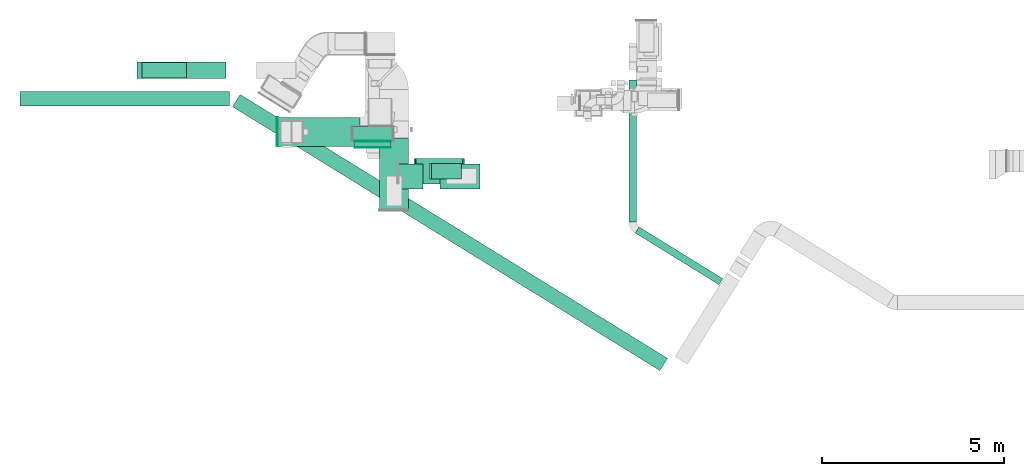
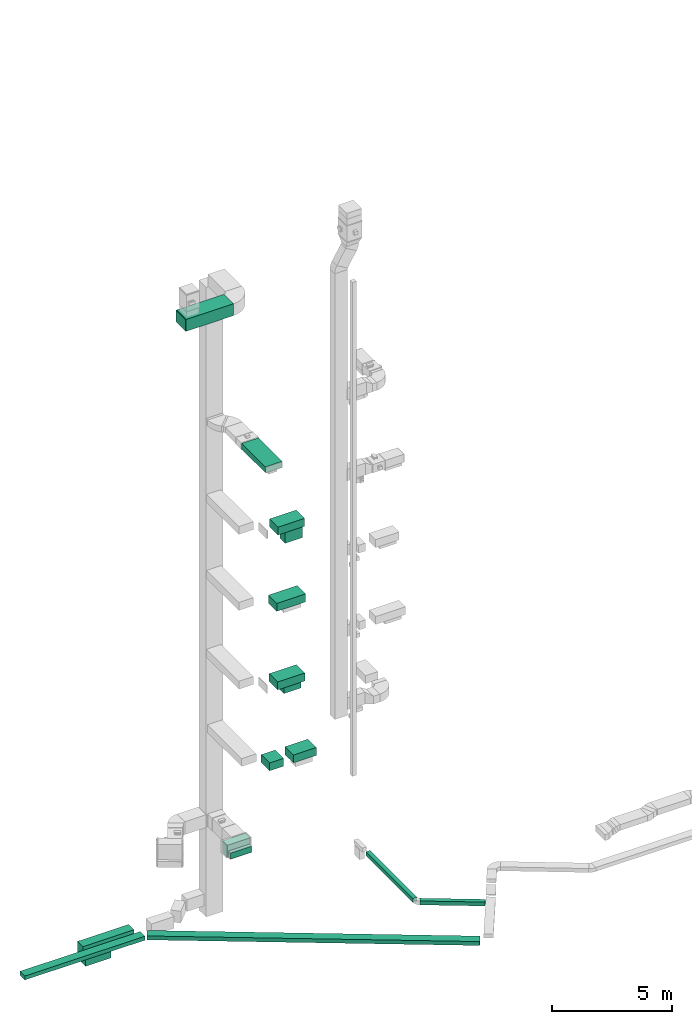
# One storey, part 5 of 25: 17 flow segments, 2 flow fittings, 1 flow terminal.
"""IFC2X3 building model written with IfcOpenShell, lengths in millimetres."""

import ifcopenshell
import ifcopenshell.guid

model = None  # the IFC model being written
_history = None  # IfcOwnerHistory: only IFC2X3 demands one
_inside = {}  # id of a spatial element -> (the spatial element, [elements in it])
_under = {}  # id of a project, library or spatial element -> (it, [spatial elements below it])
_declared = {}  # id of a project -> (the project, [libraries it declares])
_typed = {}  # id of a type object -> (the type object, [elements of that type])
_made_of = {}  # id of a material, layer set ... -> (it, [elements and type objects made of it])


def new_model(schema):
    """Start an empty IFC model of exactly this schema.

    Asked for "IFC4X3", IfcOpenShell would pick the latest addendum, in which some entities
    have other attributes; the version numbers below select the first issue.
    IFC2X3 requires an IfcOwnerHistory on every rooted entity: one is made here for all.
    """
    global model, _history
    if schema == "IFC4X3":
        model = ifcopenshell.file(schema_version=(4, 3, 0, 0))
    else:
        model = ifcopenshell.file(schema=schema)
    _inside.clear()
    _under.clear()
    _declared.clear()
    _typed.clear()
    _made_of.clear()
    _history = None
    if model.schema == "IFC2X3":
        org = make("IfcOrganization", Name="unknown")
        user = make(
            "IfcPersonAndOrganization",
            ThePerson=make("IfcPerson", FamilyName="unknown"),
            TheOrganization=org,
        )
        app = make(
            "IfcApplication",
            ApplicationDeveloper=org,
            Version="unknown",
            ApplicationFullName="unknown",
            ApplicationIdentifier="unknown",
        )
        _history = make(
            "IfcOwnerHistory",
            OwningUser=user,
            OwningApplication=app,
            ChangeAction="ADDED",
            CreationDate=0,
        )
    return model


def make(cls, **values):
    """One entity of the class cls with the attributes given. An attribute that is None is left unset."""
    return model.create_entity(
        cls, **{name: value for name, value in values.items() if value is not None}
    )


def entity(cls, *values):
    """Any entity or typed value of the class cls, its attributes in the order of the schema. None: left unset."""
    e = model.create_entity(cls)
    for i, value in enumerate(values):
        if value is not None:
            e[i] = value
    return e


def rooted(cls, **values):
    """An entity with a GlobalId (a new one), such as an element, a storey or a relation."""
    return make(cls, GlobalId=ifcopenshell.guid.new(), OwnerHistory=_history, **values)


def si_unit(unit_type, name, prefix=None):
    """IfcSIUnit, for example si_unit("LENGTHUNIT", "METRE", prefix="MILLI")."""
    return make("IfcSIUnit", UnitType=unit_type, Prefix=prefix, Name=name)


def converted_unit(unit_type, name, factor, base, dimensions=None, offset=None):
    """IfcConversionBasedUnit, such as the inch: factor (a typed value) times the base unit."""
    return make(
        "IfcConversionBasedUnit"
        if offset is None
        else "IfcConversionBasedUnitWithOffset",
        ConversionOffset=offset,
        Dimensions=None
        if dimensions is None
        else entity("IfcDimensionalExponents", *dimensions),
        UnitType=unit_type,
        Name=name,
        ConversionFactor=make(
            "IfcMeasureWithUnit", ValueComponent=factor, UnitComponent=base
        ),
    )


def derived_unit(unit_type, elements):
    """IfcDerivedUnit: a product of units, each with its exponent."""
    return make(
        "IfcDerivedUnit",
        Elements=[
            make("IfcDerivedUnitElement", Unit=unit, Exponent=power)
            for unit, power in elements
        ],
        UnitType=unit_type,
    )


def assignment(units):
    """IfcUnitAssignment: the units of a project."""
    return None if units is None else make("IfcUnitAssignment", Units=units)


def point(xyz):
    """IfcCartesianPoint."""
    return None if xyz is None else make("IfcCartesianPoint", Coordinates=xyz)


def direction(xyz):
    """IfcDirection."""
    return None if xyz is None else make("IfcDirection", DirectionRatios=xyz)


def frame(location, z_axis=None, x_axis=None):
    """IfcAxis2Placement3D, a coordinate frame: its origin and axes. An axis left out is left unset."""
    return make(
        "IfcAxis2Placement3D",
        Location=point(location),
        Axis=direction(z_axis),
        RefDirection=direction(x_axis),
    )


def frame_2d(location, x_axis=None):
    """IfcAxis2Placement2D, a coordinate frame in the plane: its origin and x axis."""
    return make(
        "IfcAxis2Placement2D", Location=point(location), RefDirection=direction(x_axis)
    )


def origin():
    """The frame at (0, 0, 0) with its axes left unset."""
    return frame((0.0, 0.0, 0.0))


def origin_2d_with_axis():
    """The frame at (0, 0) in the plane with the x axis (1, 0) written out."""
    return frame_2d((0.0, 0.0), x_axis=(1.0, 0.0))


def place(relative_to, where):
    """IfcLocalPlacement: puts the frame where relative to a parent placement (None: the world)."""
    return make(
        "IfcLocalPlacement", PlacementRelTo=relative_to, RelativePlacement=where
    )


def context(
    kind, dimensions, precision=None, world=None, true_north=None, identifier=None
):
    """IfcGeometricRepresentationContext, for example the 3D "Model" context."""
    return make(
        "IfcGeometricRepresentationContext",
        ContextIdentifier=identifier,
        ContextType=kind,
        CoordinateSpaceDimension=dimensions,
        Precision=precision,
        WorldCoordinateSystem=world,
        TrueNorth=true_north,
    )


def subcontext(parent, identifier, kind, view, scale=None):
    """IfcGeometricRepresentationSubContext, for example "Body" below "Model"."""
    return make(
        "IfcGeometricRepresentationSubContext",
        ContextIdentifier=identifier,
        ContextType=kind,
        ParentContext=parent,
        TargetScale=scale,
        TargetView=view,
    )


def project(units=None, contexts=None):
    """IfcProject with its units and contexts."""
    return rooted(
        "IfcProject",
        Name="project",
        RepresentationContexts=contexts,
        UnitsInContext=assignment(units),
    )


def spatial(cls, under=None, at=None, **own):
    """A site, building, storey or space (cls), placed at a placement, below another one or the project."""
    s = rooted(cls, ObjectPlacement=at, **own)
    if under is not None:
        _under.setdefault(under.id(), (under, []))[1].append(s)
    return s


def profile(cls, at=None, kind="AREA", **sizes):
    """A parametric profile (cls). Its sizes go by their IFC names, for example OverallWidth=200.0."""
    return make(cls, ProfileType=kind, Position=at, **sizes)


def rectangle(**sizes):
    """IfcRectangleProfileDef."""
    return profile("IfcRectangleProfileDef", **sizes)


def extrude(swept, where, along, depth):
    """IfcExtrudedAreaSolid: the profile swept, set in the frame where, extruded along a direction by depth."""
    return make(
        "IfcExtrudedAreaSolid",
        SweptArea=swept,
        Position=where,
        ExtrudedDirection=direction(along),
        Depth=depth,
    )


def shape(context_of_items, identifier, shape_type, items):
    """IfcShapeRepresentation: the items that make up one representation, for example the "Body"."""
    return make(
        "IfcShapeRepresentation",
        ContextOfItems=context_of_items,
        RepresentationIdentifier=identifier,
        RepresentationType=shape_type,
        Items=items,
    )


def source(mapping_origin, context_of_items, identifier, shape_type, items):
    """IfcRepresentationMap: a shape defined once, which mapped items show again and again."""
    return make(
        "IfcRepresentationMap",
        MappingOrigin=mapping_origin,
        MappedRepresentation=shape(context_of_items, identifier, shape_type, items),
    )


def transform(
    local_origin,
    x_axis=None,
    y_axis=None,
    z_axis=None,
    scale=None,
    scale2=None,
    scale3=None,
    uniform=True,
):
    """IfcCartesianTransformationOperator3D, or its non-uniform kind. x_axis, y_axis, z_axis: its Axis1, 2, 3."""
    if uniform:
        return make(
            "IfcCartesianTransformationOperator3D",
            Axis1=direction(x_axis),
            Axis2=direction(y_axis),
            LocalOrigin=point(local_origin),
            Scale=scale,
            Axis3=direction(z_axis),
        )
    return make(
        "IfcCartesianTransformationOperator3DnonUniform",
        Axis1=direction(x_axis),
        Axis2=direction(y_axis),
        LocalOrigin=point(local_origin),
        Scale=scale,
        Axis3=direction(z_axis),
        Scale2=scale2,
        Scale3=scale3,
    )


def mapped(mapping_source, mapping_target):
    """IfcMappedItem: shows the shape of a source again, moved by a transform."""
    return make(
        "IfcMappedItem", MappingSource=mapping_source, MappingTarget=mapping_target
    )


def material(Name=None, Category=None):
    """IfcMaterial."""
    return make("IfcMaterial", Name=Name, Category=Category)


def made_of(thing, what):
    """Note that an element or type object is made of a material, layer set ...; save() writes the relation."""
    if what is not None:
        _made_of.setdefault(what.id(), (what, []))[1].append(thing)
    return thing


def type_object(cls, material=None, **own):
    """A type object (cls), such as IfcWallType, which elements share."""
    return made_of(rooted(cls, **own), material)


def type_shapes(of_type, sources):
    """Give a type object the sources (RepresentationMaps) that its elements show as mapped items."""
    of_type.RepresentationMaps = sources


def element(
    cls,
    number,
    at=None,
    inside=None,
    cuts=None,
    type_object=None,
    material=None,
    context=None,
    identifier="Body",
    shape_type=None,
    held_by="IfcProductDefinitionShape",
    body=None,
    shapes=None,
    **own,
):
    """One element of the class cls, such as IfcWall. Its Tag is "e" and its number.

    at: its placement. inside: the storey or other place that contains it. cuts: it is an
    opening in that element (IfcRelVoidsElement). A single representation is given by context,
    identifier, shape_type and body (its items); several are given by shapes. held_by: the class
    of the entity that holds the representations. save() writes the other relations.
    """
    e = rooted(cls, Tag="e%d" % number, ObjectPlacement=at, **own)
    if body is not None:
        shapes = [shape(context, identifier, shape_type, body)]
    if shapes is not None:
        e.Representation = make(held_by, Representations=shapes)
    if inside is not None:
        _inside.setdefault(inside.id(), (inside, []))[1].append(e)
    if cuts is not None:
        rooted(
            "IfcRelVoidsElement", RelatingBuildingElement=cuts, RelatedOpeningElement=e
        )
    if type_object is not None:
        _typed.setdefault(type_object.id(), (type_object, []))[1].append(e)
    return made_of(e, material)


def aggregate(whole, parts):
    """IfcRelAggregates: a whole, such as a stair, and the parts it consists of."""
    return rooted("IfcRelAggregates", RelatingObject=whole, RelatedObjects=parts)


def save(model, path):
    """Write the relations noted so far, then the file.

    IfcRelAggregates (storeys below a building ...), IfcRelContainedInSpatialStructure (elements
    in a storey), IfcRelDefinesByType, IfcRelAssociatesMaterial and IfcRelDeclares: one each for
    every whole, place, type object, material and project.
    """
    for whole, parts in _under.values():
        aggregate(whole, parts)
    for where, things in _inside.values():
        rooted(
            "IfcRelContainedInSpatialStructure",
            RelatedElements=things,
            RelatingStructure=where,
        )
    for kind, things in _typed.values():
        rooted("IfcRelDefinesByType", RelatedObjects=things, RelatingType=kind)
    for what, things in _made_of.values():
        rooted("IfcRelAssociatesMaterial", RelatedObjects=things, RelatingMaterial=what)
    for by, libraries in _declared.values():
        rooted("IfcRelDeclares", RelatingContext=by, RelatedDefinitions=libraries)
    model.write(path)


model = new_model("IFC2X3")

# Units and contexts
model_context = context("Model", 3, precision=0.01, world=origin(), true_north=direction((6.12303176911189e-17, 1.0)))
body_context = subcontext(model_context, "Body", "Model", "MODEL_VIEW")
ifc_project = project(units=[si_unit("LENGTHUNIT", "METRE", prefix="MILLI"), si_unit("AREAUNIT", "SQUARE_METRE"), si_unit("VOLUMEUNIT", "CUBIC_METRE"), converted_unit("PLANEANGLEUNIT", "DEGREE", entity("IfcRatioMeasure", 0.0174532925199433), si_unit("PLANEANGLEUNIT", "RADIAN"), dimensions=[0, 0, 0, 0, 0, 0, 0]), si_unit("MASSUNIT", "GRAM", prefix="KILO"), derived_unit("MASSDENSITYUNIT", [(si_unit("MASSUNIT", "GRAM", prefix="KILO"), 1), (si_unit("LENGTHUNIT", "METRE"), -3)]), derived_unit("MOMENTOFINERTIAUNIT", [(si_unit("LENGTHUNIT", "METRE"), 4)]), si_unit("TIMEUNIT", "SECOND"), si_unit("FREQUENCYUNIT", "HERTZ"), si_unit("THERMODYNAMICTEMPERATUREUNIT", "DEGREE_CELSIUS"), derived_unit("THERMALTRANSMITTANCEUNIT", [(si_unit("MASSUNIT", "GRAM", prefix="KILO"), 1), (si_unit("THERMODYNAMICTEMPERATUREUNIT", "KELVIN"), -1), (si_unit("TIMEUNIT", "SECOND"), -3)]), derived_unit("VOLUMETRICFLOWRATEUNIT", [(si_unit("LENGTHUNIT", "METRE"), 3), (si_unit("TIMEUNIT", "SECOND"), -1)]), derived_unit("MASSFLOWRATEUNIT", [(si_unit("MASSUNIT", "GRAM", prefix="KILO"), 1), (si_unit("TIMEUNIT", "SECOND"), -1)]), derived_unit("ROTATIONALFREQUENCYUNIT", [(si_unit("TIMEUNIT", "SECOND"), -1)]), si_unit("ELECTRICCURRENTUNIT", "AMPERE"), si_unit("ELECTRICVOLTAGEUNIT", "VOLT"), si_unit("POWERUNIT", "WATT"), si_unit("FORCEUNIT", "NEWTON", prefix="KILO"), si_unit("ILLUMINANCEUNIT", "LUX"), si_unit("LUMINOUSFLUXUNIT", "LUMEN"), si_unit("LUMINOUSINTENSITYUNIT", "CANDELA"), derived_unit("USERDEFINED", [(si_unit("MASSUNIT", "GRAM", prefix="KILO"), -1), (si_unit("LENGTHUNIT", "METRE"), -2), (si_unit("TIMEUNIT", "SECOND"), 3), (si_unit("LUMINOUSFLUXUNIT", "LUMEN"), 1)]), derived_unit("LINEARVELOCITYUNIT", [(si_unit("LENGTHUNIT", "METRE"), 1), (si_unit("TIMEUNIT", "SECOND"), -1)]), si_unit("PRESSUREUNIT", "PASCAL"), derived_unit("USERDEFINED", [(si_unit("LENGTHUNIT", "METRE"), -2), (si_unit("MASSUNIT", "GRAM", prefix="KILO"), 1), (si_unit("TIMEUNIT", "SECOND"), -2)]), derived_unit("LINEARFORCEUNIT", [(si_unit("MASSUNIT", "GRAM", prefix="KILO"), 1), (si_unit("LENGTHUNIT", "METRE"), 1), (si_unit("TIMEUNIT", "SECOND"), -2), (si_unit("LENGTHUNIT", "METRE"), -1)]), derived_unit("PLANARFORCEUNIT", [(si_unit("MASSUNIT", "GRAM", prefix="KILO"), 1), (si_unit("LENGTHUNIT", "METRE"), 1), (si_unit("TIMEUNIT", "SECOND"), -2), (si_unit("LENGTHUNIT", "METRE"), -2)])], contexts=[model_context])

# Site, building, storey
site_placement = place(None, origin())
site = spatial("IfcSite", under=ifc_project, at=site_placement, CompositionType="ELEMENT")
building_placement = place(site_placement, origin())
building = spatial("IfcBuilding", under=site, at=building_placement, CompositionType="ELEMENT")
storey_placement = place(building_placement, origin())
storey = spatial("IfcBuildingStorey", under=building, at=storey_placement, CompositionType="ELEMENT", Elevation=0.0)

# Flow segments
duct_segment_type_1 = type_object("IfcDuctSegmentType", PredefinedType="NOTDEFINED")
flow_segment_1_placement = place(storey_placement, frame((-5375.43, 14592.06, -1100.0)))
element("IfcFlowSegment", 1, at=flow_segment_1_placement, inside=storey, type_object=duct_segment_type_1, context=body_context, shape_type="SweptSolid", body=[
    extrude(rectangle(XDim=5771.90420210275, YDim=400.0, at=origin_2d_with_axis()), frame((2885.95, 200.0, 0.0)), (0.0, 0.0, 1.0), 200.0),
])
flow_segment_2_placement = place(storey_placement, frame((11565.9, 9667.02, -1100.0)))
element("IfcFlowSegment", 2, at=flow_segment_2_placement, inside=storey, type_object=duct_segment_type_1, context=body_context, shape_type="SweptSolid", body=[
    extrude(rectangle(XDim=2711.86979617274, YDim=199.999999999998, at=origin_2d_with_axis()), frame((1206.16, 797.64, 0.0), z_axis=(0.0, 0.0, 1.0), x_axis=(0.850783354162399, -0.525516588016189, 0.0)), (0.0, 0.0, 1.0), 200.0),
])
flow_segment_3_placement = place(storey_placement, frame((3785.85, 13632.5, 2500.0)))
element("IfcFlowSegment", 3, at=flow_segment_3_placement, inside=storey, type_object=duct_segment_type_1, context=body_context, shape_type="SweptSolid", body=[
    extrude(rectangle(XDim=1100.0, YDim=400.0, at=origin_2d_with_axis()), frame((550.0, 200.0, 0.0)), (0.0, 0.0, 1.0), 600.0),
])
flow_segment_4_placement = place(storey_placement, frame((5049.45, 12300.47, 7250.0)))
element("IfcFlowSegment", 4, at=flow_segment_4_placement, inside=storey, type_object=duct_segment_type_1, context=body_context, shape_type="SweptSolid", body=[
    extrude(rectangle(XDim=665.48850074056, YDim=699.999999999999, at=origin_2d_with_axis()), frame((332.74, 350.0, 0.0), z_axis=(0.0, 0.0, 1.0), x_axis=(-1.0, 0.0, 0.0)), (0.0, 0.0, 1.0), 400.0),
])
flow_segment_5_placement = place(storey_placement, frame((475.27, 7302.46, -1100.0)))
element("IfcFlowSegment", 5, at=flow_segment_5_placement, inside=storey, type_object=duct_segment_type_1, context=body_context, shape_type="SweptSolid", body=[
    extrude(rectangle(XDim=13833.2016747026, YDim=400.000000000002, at=origin_2d_with_axis()), frame((5990.32, 3803.8, 0.0), z_axis=(0.0, 0.0, 1.0), x_axis=(0.850887908023427, -0.525347283213224, 0.0)), (0.0, 0.0, 1.0), 200.0),
])
flow_segment_6_placement = place(storey_placement, frame((11399.83, 11389.92, -1100.0)))
element("IfcFlowSegment", 6, at=flow_segment_6_placement, inside=storey, type_object=duct_segment_type_1, context=body_context, shape_type="SweptSolid", body=[
    extrude(rectangle(XDim=3910.05184285594, YDim=200.0, at=origin_2d_with_axis()), frame((100.0, 1955.03, 0.0), z_axis=(0.0, 0.0, 1.0), x_axis=(0.0, 1.0, 0.0)), (0.0, 0.0, 1.0), 200.0),
])
duct_segment_type_2 = type_object("IfcDuctSegmentType", PredefinedType="NOTDEFINED")
flow_segment_7_placement = place(storey_placement, frame((5959.69, 12587.16, 18300.0)))
element("IfcFlowSegment", 7, at=flow_segment_7_placement, inside=storey, type_object=duct_segment_type_2, context=body_context, shape_type="SweptSolid", body=[
    extrude(rectangle(XDim=825.0, YDim=425.000000000001, at=origin_2d_with_axis()), frame((412.5, 212.5, 0.0), z_axis=(0.0, 0.0, 1.0), x_axis=(-1.0, 0.0, 0.0)), (0.0, 0.0, 1.0), 629.999999999982),
])
flow_segment_8_placement = place(storey_placement, frame((1723.33, 13477.57, 30000.0)))
element("IfcFlowSegment", 8, at=flow_segment_8_placement, inside=storey, type_object=duct_segment_type_2, context=body_context, shape_type="SweptSolid", body=[
    extrude(rectangle(XDim=2270.00000000001, YDim=800.0, at=origin_2d_with_axis()), frame((1135.0, 400.0, 0.0), z_axis=(0.0, 0.0, 1.0), x_axis=(-1.0, 0.0, 0.0)), (0.0, 0.0, 1.0), 600.000000000002),
])
flow_segment_9_placement = place(storey_placement, frame((4519.66, 11729.53, 22900.0)))
element("IfcFlowSegment", 9, at=flow_segment_9_placement, inside=storey, type_object=duct_segment_type_2, context=body_context, shape_type="SweptSolid", body=[
    extrude(rectangle(XDim=1972.07412336472, YDim=800.0, at=origin_2d_with_axis()), frame((400.0, 986.04, 0.0), z_axis=(0.0, 0.0, 1.0), x_axis=(0.0, -1.0, 0.0)), (0.0, 0.0, 1.0), 300.000000000001),
])
flow_segment_10_placement = place(storey_placement, frame((5529.65, 12449.66, 18950.0)))
element("IfcFlowSegment", 10, at=flow_segment_10_placement, inside=storey, type_object=duct_segment_type_2, context=body_context, shape_type="SweptSolid", body=[
    extrude(rectangle(XDim=1282.07783646253, YDim=700.000000000001, at=origin_2d_with_axis()), frame((641.04, 350.0, 0.0)), (0.0, 0.0, 1.0), 400.0),
])
flow_segment_11_placement = place(storey_placement, frame((5480.45, 12449.66, 15100.0)))
element("IfcFlowSegment", 11, at=flow_segment_11_placement, inside=storey, type_object=duct_segment_type_2, context=body_context, shape_type="SweptSolid", body=[
    extrude(rectangle(XDim=1381.27586816547, YDim=699.999999999999, at=origin_2d_with_axis()), frame((690.64, 350.0, 0.0)), (0.0, 0.0, 1.0), 400.0),
])
flow_segment_12_placement = place(storey_placement, frame((5519.65, 12449.66, 11100.0)))
element("IfcFlowSegment", 12, at=flow_segment_12_placement, inside=storey, type_object=duct_segment_type_2, context=body_context, shape_type="SweptSolid", body=[
    extrude(rectangle(XDim=1310.0, YDim=699.999999999999, at=origin_2d_with_axis()), frame((655.0, 350.0, 0.0)), (0.0, 0.0, 1.0), 400.0),
])
flow_segment_13_placement = place(storey_placement, frame((5894.88, 12587.16, 10700.0)))
element("IfcFlowSegment", 13, at=flow_segment_13_placement, inside=storey, type_object=duct_segment_type_2, context=body_context, shape_type="SweptSolid", body=[
    extrude(rectangle(XDim=825.0, YDim=425.000000000001, at=origin_2d_with_axis()), frame((412.5, 212.5, 0.0), z_axis=(0.0, 0.0, 1.0), x_axis=(-1.0, 0.0, 0.0)), (0.0, 0.0, 1.0), 379.999999999992),
])
flow_segment_14_placement = place(storey_placement, frame((3838.74, 13450.1, 2500.0)))
element("IfcFlowSegment", 14, at=flow_segment_14_placement, inside=storey, type_object=duct_segment_type_2, context=body_context, shape_type="SweptSolid", body=[
    extrude(rectangle(XDim=162.39827932573, YDim=1000.0, at=origin_2d_with_axis()), frame((500.0, 81.2, 0.0), z_axis=(0.0, 0.0, 1.0), x_axis=(0.0, 1.0, 0.0)), (0.0, 0.0, 1.0), 300.0),
])
flow_segment_15_placement = place(storey_placement, frame((-2154.56, 15350.1, -1600.0)))
element("IfcFlowSegment", 15, at=flow_segment_15_placement, inside=storey, type_object=duct_segment_type_2, context=body_context, shape_type="SweptSolid", body=[
    extrude(rectangle(XDim=2454.67069149708, YDim=449.999999999999, at=origin_2d_with_axis()), frame((1227.34, 225.0, 0.0), z_axis=(0.0, 0.0, 1.0), x_axis=(-1.0, 0.0, 0.0)), (0.0, 0.0, 1.0), 600.0),
])
flow_segment_16_placement = place(storey_placement, frame((-2012.5, 15362.6, -2050.0)))
element("IfcFlowSegment", 16, at=flow_segment_16_placement, inside=storey, type_object=duct_segment_type_2, context=body_context, shape_type="SweptSolid", body=[
    extrude(rectangle(XDim=1225.0, YDim=425.000000000001, at=origin_2d_with_axis()), frame((612.5, 212.5, 0.0), z_axis=(0.0, 0.0, 1.0), x_axis=(-1.0, 0.0, 0.0)), (0.0, 0.0, 1.0), 430.0),
])
flow_segment_17_placement = place(storey_placement, frame((6194.94, 12300.47, 7250.0)))
element("IfcFlowSegment", 17, at=flow_segment_17_placement, inside=storey, type_object=duct_segment_type_2, context=body_context, shape_type="SweptSolid", body=[
    extrude(rectangle(XDim=1094.22665279493, YDim=699.999999999999, at=origin_2d_with_axis()), frame((547.11, 350.0, 0.0), z_axis=(0.0, 0.0, 1.0), x_axis=(-1.0, 0.0, 0.0)), (0.0, 0.0, 1.0), 400.0),
])

# Flow fitting
ifc_material_1 = material()
duct_fitting_type_1 = type_object("IfcDuctFittingType", PredefinedType="NOTDEFINED", material=ifc_material_1)
shared_shape_1 = source(origin(), body_context, "Body", "SweptSolid", [
    extrude(rectangle(XDim=24.9999999999999, YDim=800.0, at=origin_2d_with_axis()), frame((12.5, 0.0, -300.0)), (0.0, 0.0, 1.0), 600.0),
])
type_shapes(duct_fitting_type_1, [shared_shape_1])
flow_fitting_1_placement = place(storey_placement, frame((1723.33, 13877.57, 30300.0), z_axis=(0.0, 0.0, 1.0), x_axis=(-1.0, 0.0, 0.0)))
element("IfcFlowFitting", 18, at=flow_fitting_1_placement, inside=storey, type_object=duct_fitting_type_1, material=ifc_material_1, context=body_context, shape_type="MappedRepresentation", body=[
    mapped(shared_shape_1, transform((0.0, 0.0, 0.0), scale=1.0)),
])

# Flow terminal
ifc_material_2 = material()
air_terminal_type = type_object("IfcAirTerminalType", PredefinedType="NOTDEFINED", material=ifc_material_2)
shared_shape_2 = source(origin(), body_context, "Body", "SweptSolid", [
    extrude(rectangle(XDim=4.0, YDim=999.999999999999, at=origin_2d_with_axis()), frame((0.0, -2.0, -150.0), z_axis=(0.0, 0.0, 1.0), x_axis=(0.0, 1.0, 0.0)), (0.0, 0.0, 1.0), 300.000000000005),
])
type_shapes(air_terminal_type, [shared_shape_2])
flow_terminal_placement = place(storey_placement, frame((4338.74, 13450.1, 2650.0)))
element("IfcFlowTerminal", 19, at=flow_terminal_placement, inside=storey, type_object=air_terminal_type, material=ifc_material_2, context=body_context, shape_type="MappedRepresentation", body=[
    mapped(shared_shape_2, transform((0.0, 0.0, 0.0), scale=1.0)),
])

# Flow fitting
duct_fitting_type_2 = type_object("IfcDuctFittingType", PredefinedType="NOTDEFINED", material=ifc_material_1)
shared_shape_3 = source(origin(), body_context, "Body", "SweptSolid", [
    extrude(rectangle(XDim=26.0960000000015, YDim=1000.0, at=origin_2d_with_axis()), frame((6.95, 0.0, -150.0)), (0.0, 0.0, 1.0), 300.0),
])
type_shapes(duct_fitting_type_2, [shared_shape_3])
flow_fitting_2_placement = place(storey_placement, frame((4338.74, 13632.5, 2650.0), z_axis=(0.0, 0.0, -1.0), x_axis=(0.0, -1.0, 0.0)))
element("IfcFlowFitting", 20, at=flow_fitting_2_placement, inside=storey, type_object=duct_fitting_type_2, material=ifc_material_1, context=body_context, shape_type="MappedRepresentation", body=[
    mapped(shared_shape_3, transform((0.0, 0.0, 0.0), scale=1.0)),
])

save(model, "model.ifc")
